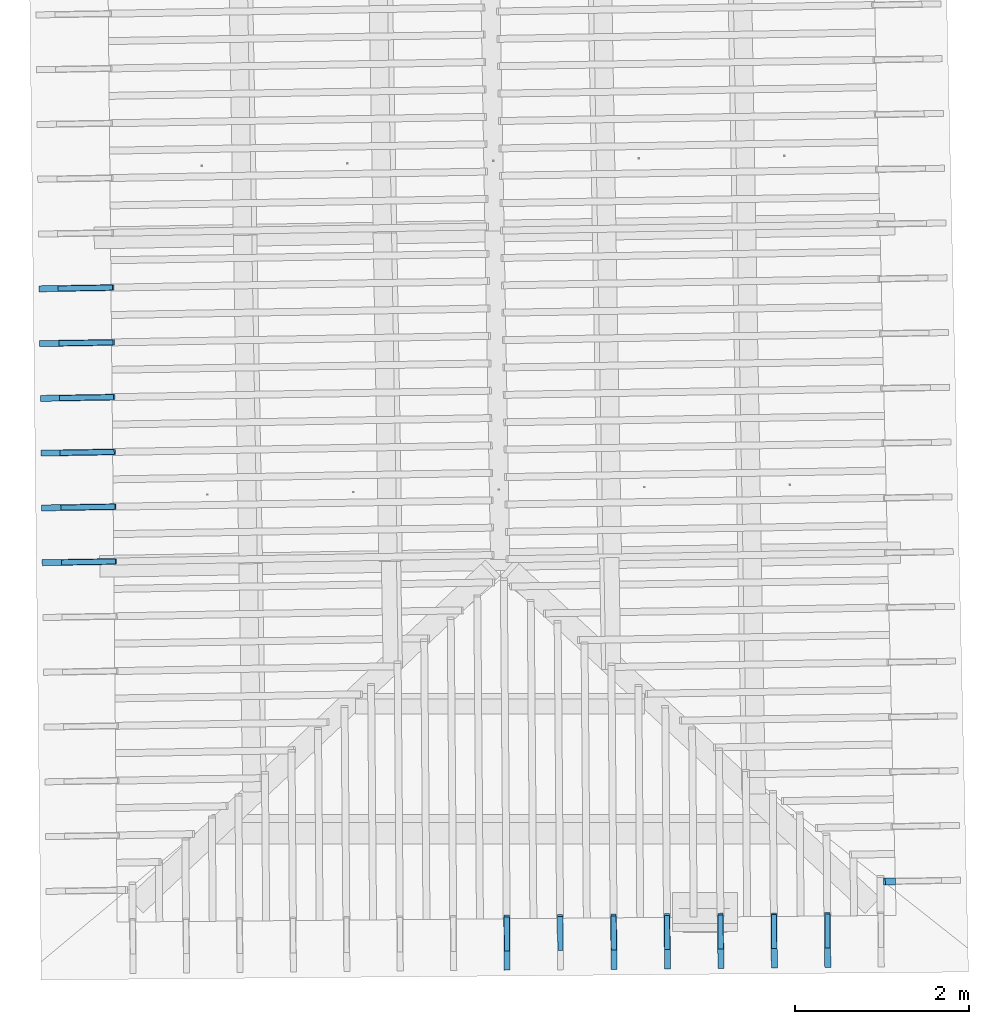
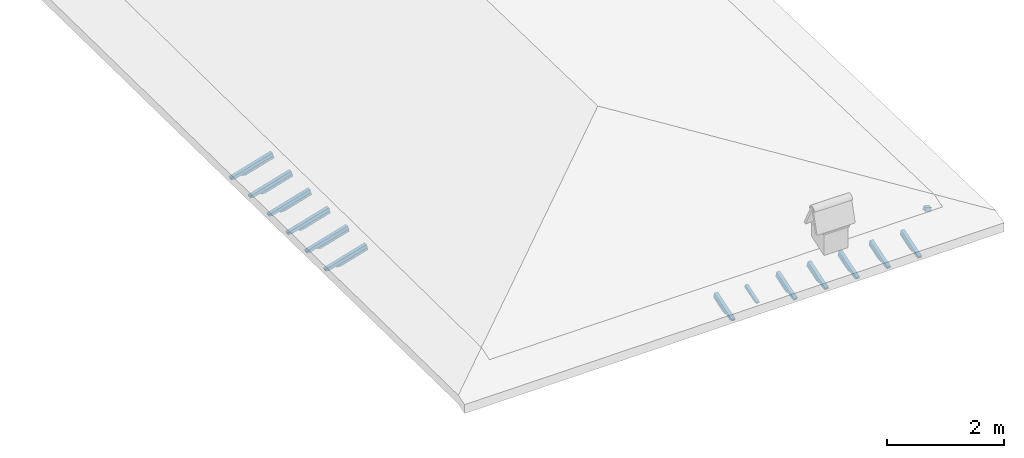
# One storey, part 10 of 19: 26 beams, 5 elements without a shape of their own.
"""IFC4 building model written with IfcOpenShell, lengths in metres."""

import ifcopenshell
import ifcopenshell.guid

model = None  # the IFC model being written
_history = None  # IfcOwnerHistory: only IFC2X3 demands one
_inside = {}  # id of a spatial element -> (the spatial element, [elements in it])
_under = {}  # id of a project, library or spatial element -> (it, [spatial elements below it])
_declared = {}  # id of a project -> (the project, [libraries it declares])
_typed = {}  # id of a type object -> (the type object, [elements of that type])
_made_of = {}  # id of a material, layer set ... -> (it, [elements and type objects made of it])


def new_model(schema):
    """Start an empty IFC model of exactly this schema.

    Asked for "IFC4X3", IfcOpenShell would pick the latest addendum, in which some entities
    have other attributes; the version numbers below select the first issue.
    IFC2X3 requires an IfcOwnerHistory on every rooted entity: one is made here for all.
    """
    global model, _history
    if schema == "IFC4X3":
        model = ifcopenshell.file(schema_version=(4, 3, 0, 0))
    else:
        model = ifcopenshell.file(schema=schema)
    _inside.clear()
    _under.clear()
    _declared.clear()
    _typed.clear()
    _made_of.clear()
    _history = None
    if model.schema == "IFC2X3":
        org = make("IfcOrganization", Name="unknown")
        user = make(
            "IfcPersonAndOrganization",
            ThePerson=make("IfcPerson", FamilyName="unknown"),
            TheOrganization=org,
        )
        app = make(
            "IfcApplication",
            ApplicationDeveloper=org,
            Version="unknown",
            ApplicationFullName="unknown",
            ApplicationIdentifier="unknown",
        )
        _history = make(
            "IfcOwnerHistory",
            OwningUser=user,
            OwningApplication=app,
            ChangeAction="ADDED",
            CreationDate=0,
        )
    return model


def make(cls, **values):
    """One entity of the class cls with the attributes given. An attribute that is None is left unset."""
    return model.create_entity(
        cls, **{name: value for name, value in values.items() if value is not None}
    )


def entity(cls, *values):
    """Any entity or typed value of the class cls, its attributes in the order of the schema. None: left unset."""
    e = model.create_entity(cls)
    for i, value in enumerate(values):
        if value is not None:
            e[i] = value
    return e


def rooted(cls, **values):
    """An entity with a GlobalId (a new one), such as an element, a storey or a relation."""
    return make(cls, GlobalId=ifcopenshell.guid.new(), OwnerHistory=_history, **values)


def si_unit(unit_type, name, prefix=None):
    """IfcSIUnit, for example si_unit("LENGTHUNIT", "METRE", prefix="MILLI")."""
    return make("IfcSIUnit", UnitType=unit_type, Prefix=prefix, Name=name)


def converted_unit(unit_type, name, factor, base, dimensions=None, offset=None):
    """IfcConversionBasedUnit, such as the inch: factor (a typed value) times the base unit."""
    return make(
        "IfcConversionBasedUnit"
        if offset is None
        else "IfcConversionBasedUnitWithOffset",
        ConversionOffset=offset,
        Dimensions=None
        if dimensions is None
        else entity("IfcDimensionalExponents", *dimensions),
        UnitType=unit_type,
        Name=name,
        ConversionFactor=make(
            "IfcMeasureWithUnit", ValueComponent=factor, UnitComponent=base
        ),
    )


def derived_unit(unit_type, elements):
    """IfcDerivedUnit: a product of units, each with its exponent."""
    return make(
        "IfcDerivedUnit",
        Elements=[
            make("IfcDerivedUnitElement", Unit=unit, Exponent=power)
            for unit, power in elements
        ],
        UnitType=unit_type,
    )


def assignment(units):
    """IfcUnitAssignment: the units of a project."""
    return None if units is None else make("IfcUnitAssignment", Units=units)


def point(xyz):
    """IfcCartesianPoint."""
    return None if xyz is None else make("IfcCartesianPoint", Coordinates=xyz)


def direction(xyz):
    """IfcDirection."""
    return None if xyz is None else make("IfcDirection", DirectionRatios=xyz)


def frame(location, z_axis=None, x_axis=None):
    """IfcAxis2Placement3D, a coordinate frame: its origin and axes. An axis left out is left unset."""
    return make(
        "IfcAxis2Placement3D",
        Location=point(location),
        Axis=direction(z_axis),
        RefDirection=direction(x_axis),
    )


def origin():
    """The frame at (0, 0, 0) with its axes left unset."""
    return frame((0.0, 0.0, 0.0))


def place(relative_to, where):
    """IfcLocalPlacement: puts the frame where relative to a parent placement (None: the world)."""
    return make(
        "IfcLocalPlacement", PlacementRelTo=relative_to, RelativePlacement=where
    )


def context(
    kind, dimensions, precision=None, world=None, true_north=None, identifier=None
):
    """IfcGeometricRepresentationContext, for example the 3D "Model" context."""
    return make(
        "IfcGeometricRepresentationContext",
        ContextIdentifier=identifier,
        ContextType=kind,
        CoordinateSpaceDimension=dimensions,
        Precision=precision,
        WorldCoordinateSystem=world,
        TrueNorth=true_north,
    )


def subcontext(parent, identifier, kind, view, scale=None):
    """IfcGeometricRepresentationSubContext, for example "Body" below "Model"."""
    return make(
        "IfcGeometricRepresentationSubContext",
        ContextIdentifier=identifier,
        ContextType=kind,
        ParentContext=parent,
        TargetScale=scale,
        TargetView=view,
    )


def project(units=None, contexts=None):
    """IfcProject with its units and contexts."""
    return rooted(
        "IfcProject",
        Name="project",
        RepresentationContexts=contexts,
        UnitsInContext=assignment(units),
    )


def spatial(cls, under=None, at=None, **own):
    """A site, building, storey or space (cls), placed at a placement, below another one or the project."""
    s = rooted(cls, ObjectPlacement=at, **own)
    if under is not None:
        _under.setdefault(under.id(), (under, []))[1].append(s)
    return s


def point_list(points):
    """IfcCartesianPointList2D or 3D."""
    cls = (
        "IfcCartesianPointList2D" if len(points[0]) == 2 else "IfcCartesianPointList3D"
    )
    return make(cls, CoordList=points)


def line(*indices):
    """IfcLineIndex: a straight run through numbered points of an indexed curve."""
    return model.create_entity("IfcLineIndex", indices)


def arc(*indices):
    """IfcArcIndex: an arc through three numbered points of an indexed curve."""
    return model.create_entity("IfcArcIndex", indices)


def indexed_curve(points, segments=None, self_intersect=None):
    """IfcIndexedPolyCurve: lines and arcs through numbered points (the first is 1)."""
    return make(
        "IfcIndexedPolyCurve",
        Points=point_list(points),
        Segments=segments,
        SelfIntersect=self_intersect,
    )


def outline(outer, holes=None, kind="AREA"):
    """IfcArbitraryClosedProfileDef: a profile drawn as a closed curve; with holes, ...WithVoids."""
    if holes is None:
        return make("IfcArbitraryClosedProfileDef", ProfileType=kind, OuterCurve=outer)
    return make(
        "IfcArbitraryProfileDefWithVoids",
        ProfileType=kind,
        OuterCurve=outer,
        InnerCurves=holes,
    )


def extrude(swept, where, along, depth):
    """IfcExtrudedAreaSolid: the profile swept, set in the frame where, extruded along a direction by depth."""
    return make(
        "IfcExtrudedAreaSolid",
        SweptArea=swept,
        Position=where,
        ExtrudedDirection=direction(along),
        Depth=depth,
    )


def shape(context_of_items, identifier, shape_type, items):
    """IfcShapeRepresentation: the items that make up one representation, for example the "Body"."""
    return make(
        "IfcShapeRepresentation",
        ContextOfItems=context_of_items,
        RepresentationIdentifier=identifier,
        RepresentationType=shape_type,
        Items=items,
    )


def source(mapping_origin, context_of_items, identifier, shape_type, items):
    """IfcRepresentationMap: a shape defined once, which mapped items show again and again."""
    return make(
        "IfcRepresentationMap",
        MappingOrigin=mapping_origin,
        MappedRepresentation=shape(context_of_items, identifier, shape_type, items),
    )


def transform(
    local_origin,
    x_axis=None,
    y_axis=None,
    z_axis=None,
    scale=None,
    scale2=None,
    scale3=None,
    uniform=True,
):
    """IfcCartesianTransformationOperator3D, or its non-uniform kind. x_axis, y_axis, z_axis: its Axis1, 2, 3."""
    if uniform:
        return make(
            "IfcCartesianTransformationOperator3D",
            Axis1=direction(x_axis),
            Axis2=direction(y_axis),
            LocalOrigin=point(local_origin),
            Scale=scale,
            Axis3=direction(z_axis),
        )
    return make(
        "IfcCartesianTransformationOperator3DnonUniform",
        Axis1=direction(x_axis),
        Axis2=direction(y_axis),
        LocalOrigin=point(local_origin),
        Scale=scale,
        Axis3=direction(z_axis),
        Scale2=scale2,
        Scale3=scale3,
    )


def mapped(mapping_source, mapping_target):
    """IfcMappedItem: shows the shape of a source again, moved by a transform."""
    return make(
        "IfcMappedItem", MappingSource=mapping_source, MappingTarget=mapping_target
    )


def material(Name=None, Category=None):
    """IfcMaterial."""
    return make("IfcMaterial", Name=Name, Category=Category)


def made_of(thing, what):
    """Note that an element or type object is made of a material, layer set ...; save() writes the relation."""
    if what is not None:
        _made_of.setdefault(what.id(), (what, []))[1].append(thing)
    return thing


def type_object(cls, material=None, **own):
    """A type object (cls), such as IfcWallType, which elements share."""
    return made_of(rooted(cls, **own), material)


def type_shapes(of_type, sources):
    """Give a type object the sources (RepresentationMaps) that its elements show as mapped items."""
    of_type.RepresentationMaps = sources


def element(
    cls,
    number,
    at=None,
    inside=None,
    cuts=None,
    type_object=None,
    material=None,
    context=None,
    identifier="Body",
    shape_type=None,
    held_by="IfcProductDefinitionShape",
    body=None,
    shapes=None,
    **own,
):
    """One element of the class cls, such as IfcWall. Its Tag is "e" and its number.

    at: its placement. inside: the storey or other place that contains it. cuts: it is an
    opening in that element (IfcRelVoidsElement). A single representation is given by context,
    identifier, shape_type and body (its items); several are given by shapes. held_by: the class
    of the entity that holds the representations. save() writes the other relations.
    """
    e = rooted(cls, Tag="e%d" % number, ObjectPlacement=at, **own)
    if body is not None:
        shapes = [shape(context, identifier, shape_type, body)]
    if shapes is not None:
        e.Representation = make(held_by, Representations=shapes)
    if inside is not None:
        _inside.setdefault(inside.id(), (inside, []))[1].append(e)
    if cuts is not None:
        rooted(
            "IfcRelVoidsElement", RelatingBuildingElement=cuts, RelatedOpeningElement=e
        )
    if type_object is not None:
        _typed.setdefault(type_object.id(), (type_object, []))[1].append(e)
    return made_of(e, material)


def aggregate(whole, parts):
    """IfcRelAggregates: a whole, such as a stair, and the parts it consists of."""
    return rooted("IfcRelAggregates", RelatingObject=whole, RelatedObjects=parts)


def save(model, path):
    """Write the relations noted so far, then the file.

    IfcRelAggregates (storeys below a building ...), IfcRelContainedInSpatialStructure (elements
    in a storey), IfcRelDefinesByType, IfcRelAssociatesMaterial and IfcRelDeclares: one each for
    every whole, place, type object, material and project.
    """
    for whole, parts in _under.values():
        aggregate(whole, parts)
    for where, things in _inside.values():
        rooted(
            "IfcRelContainedInSpatialStructure",
            RelatedElements=things,
            RelatingStructure=where,
        )
    for kind, things in _typed.values():
        rooted("IfcRelDefinesByType", RelatedObjects=things, RelatingType=kind)
    for what, things in _made_of.values():
        rooted("IfcRelAssociatesMaterial", RelatedObjects=things, RelatingMaterial=what)
    for by, libraries in _declared.values():
        rooted("IfcRelDeclares", RelatingContext=by, RelatedDefinitions=libraries)
    model.write(path)


model = new_model("IFC4")

# Units and contexts
model_context = context("Model", 3, precision=1e-05, world=origin(), true_north=direction((6.123233995736766e-17, 1.0)))
body_context = subcontext(model_context, "Body", "Model", "MODEL_VIEW")
ifc_project = project(units=[si_unit("LENGTHUNIT", "METRE"), si_unit("AREAUNIT", "SQUARE_METRE"), si_unit("VOLUMEUNIT", "CUBIC_METRE"), converted_unit("PLANEANGLEUNIT", "DEGREE", entity("IfcPlaneAngleMeasure", 0.017453292519943278), si_unit("PLANEANGLEUNIT", "RADIAN"), dimensions=[0, 0, 0, 0, 0, 0, 0]), derived_unit("THERMALTRANSMITTANCEUNIT", [(si_unit("MASSUNIT", "GRAM", prefix="KILO"), 1), (si_unit("THERMODYNAMICTEMPERATUREUNIT", "KELVIN"), -1), (si_unit("TIMEUNIT", "SECOND"), -3)])], contexts=[model_context])

# Site, building, storey
site_placement = place(None, origin())
site = spatial("IfcSite", under=ifc_project, at=site_placement, CompositionType="ELEMENT")
building_placement = place(site_placement, origin())
building = spatial("IfcBuilding", under=site, at=building_placement, CompositionType="ELEMENT")
storey_placement = place(building_placement, frame((0.0, 0.0, 3.28)))
storey = spatial("IfcBuildingStorey", under=building, at=storey_placement, Name="Livello Copertura", CompositionType="ELEMENT", Elevation=3.28)

# Assembly, beam
assembly_1_placement = place(storey_placement, origin())
assembly_1 = element("IfcElementAssembly", 1, at=assembly_1_placement, inside=storey, Name="Sistema di travi strutturali:Sistema di travi strutturali", ObjectType="Sistema di travi strutturali:Sistema di travi strutturali", AssemblyPlace="NOTDEFINED", PredefinedType="BEAM_GRID")
ifc_material = material(Name="Legno - Legno da costruzione", Category="Legno")
beam_type_1 = type_object("IfcBeamType", Name="Legno:80x80", PredefinedType="JOIST", material=ifc_material)
shared_shape_1 = source(origin(), body_context, "Body", "SweptSolid", [
    extrude(outline(indexed_curve([(-0.06, -0.04000000000000169), (0.06, -0.04000000000000169), (0.06, 0.04000000000000169), (-0.06, 0.04000000000000169), (-0.06, -0.04000000000000169)], self_intersect=False)), frame((0.0, 0.0, -0.040000000000005476), z_axis=(0.0, 0.0, 1.0), x_axis=(-1.0, 0.0, 0.0)), (0.0, 0.0, 1.0), 0.07999999999999997),
])
type_shapes(beam_type_1, [shared_shape_1])
beam_1_placement = place(assembly_1_placement, frame((4.366833292213961, -2.753231039773949, 0.09177934520169773), z_axis=(0.2688805697492502, 0.00459446744066822, 0.9631625667976592), x_axis=(-0.9630219859926796, -0.01645553326302712, 0.26891982061526215)))
beam_1 = element("IfcBeam", 2, at=beam_1_placement, type_object=beam_type_1, material=ifc_material, Name="Legno:80x80", ObjectType="Legno:80x80", PredefinedType="JOIST", context=body_context, shape_type="MappedRepresentation", body=[
    mapped(shared_shape_1, transform((0.0, 0.0, 0.0), scale=1.0)),
])
aggregate(assembly_1, [beam_1])

# Assembly, beams
assembly_2_placement = place(storey_placement, origin())
assembly_2 = element("IfcElementAssembly", 3, at=assembly_2_placement, inside=storey, Name="Sistema di travi strutturali:Sistema di travi strutturali", ObjectType="Sistema di travi strutturali:Sistema di travi strutturali", AssemblyPlace="NOTDEFINED", PredefinedType="BEAM_GRID")
beam_type_2 = type_object("IfcBeamType", Name="70x70:70x70", PredefinedType="JOIST", material=ifc_material)
shared_shape_2 = source(origin(), body_context, "Body", "SweptSolid", [
    extrude(outline(indexed_curve([(-0.04357142857143147, -0.5739999999999993), (0.02642857142856851, -0.5739999999999993), (0.02642857142856851, 0.18000000000000033), (0.01242857142858439, 0.17999999999999694), (0.026181867029378907, 0.20370960452790157), (0.018428571428570677, 0.23000000000000062), (0.006014118110847642, 0.25299557551498353), (0.003428571428570844, 0.2790000000000004), (-0.04357142857143147, 0.2790000000000004)], segments=[line(1, 2, 3, 4), arc(4, 5, 6), arc(6, 7, 8), line(8, 9, 1)], self_intersect=False)), frame((-0.11249999999999936, -0.03500000000000078, -0.008571428571433209), z_axis=(0.0, 1.0, 0.0), x_axis=(0.0, 0.0, -1.0)), (0.0, 0.0, 1.0), 0.06999999999999999),
])
type_shapes(beam_type_2, [shared_shape_2])
beam_2_placement = place(assembly_2_placement, frame((-4.988717104860706, 0.9183690082744996, 0.09825853585725741), z_axis=(-0.26888056974925334, -0.004594467440668785, 0.9631625667976583), x_axis=(0.9630219859926786, 0.016455533263033065, 0.2689198206152653)))
beam_2 = element("IfcBeam", 4, at=beam_2_placement, type_object=beam_type_2, material=ifc_material, Name="70x70:70x70", ObjectType="70x70:70x70", PredefinedType="JOIST", context=body_context, shape_type="MappedRepresentation", body=[
    mapped(shared_shape_2, transform((0.0, 0.0, 0.0), scale=1.0)),
])
beam_type_3 = type_object("IfcBeamType", Name="70x70:70x70", PredefinedType="JOIST", material=ifc_material)
shared_shape_3 = source(origin(), body_context, "Body", "SweptSolid", [
    extrude(outline(indexed_curve([(-0.04357142857143148, -0.575428571428571), (0.02642857142856849, -0.575428571428571), (0.02642857142856849, 0.18057142857142902), (0.012428571428584383, 0.18057142857142564), (0.0261818670293789, 0.20428103309933027), (0.018428571428570715, 0.23057142857142915), (0.006014118110847679, 0.2535670040864121), (0.00342857142857088, 0.27957142857142897), (-0.04357142857143148, 0.27957142857142897)], segments=[line(1, 2, 3, 4), arc(4, 5, 6), arc(6, 7, 8), line(8, 9, 1)], self_intersect=False)), frame((-0.11292857142857085, -0.03500000000000078, -0.008571428571433224), z_axis=(0.0, 1.0, 0.0), x_axis=(0.0, 0.0, -1.0)), (0.0, 0.0, 1.0), 0.06999999999999999),
])
type_shapes(beam_type_3, [shared_shape_3])
beam_3_placement = place(assembly_2_placement, frame((-4.995498480005348, 1.5483450989168117, 0.09937052324256612), z_axis=(-0.2688805697492535, -0.004594467440668792, 0.9631625667976582), x_axis=(0.9630219859926785, 0.016455533263032975, 0.2689198206152655)))
beam_3 = element("IfcBeam", 5, at=beam_3_placement, type_object=beam_type_3, material=ifc_material, Name="70x70:70x70", ObjectType="70x70:70x70", PredefinedType="JOIST", context=body_context, shape_type="MappedRepresentation", body=[
    mapped(shared_shape_3, transform((0.0, 0.0, 0.0), scale=1.0)),
])
beam_type_4 = type_object("IfcBeamType", Name="70x70:70x70", PredefinedType="JOIST", material=ifc_material)
shared_shape_4 = source(origin(), body_context, "Body", "SweptSolid", [
    extrude(outline(indexed_curve([(-0.04357142857143152, -0.5761428571428567), (0.026428571428568467, -0.5761428571428567), (0.026428571428568467, 0.18085714285714335), (0.012428571428584369, 0.18085714285714), (0.026181867029378886, 0.20456674738504463), (0.018428571428570784, 0.2308571428571435), (0.006014118110847748, 0.2538527183721264), (0.003428571428570954, 0.2798571428571433), (-0.04357142857143152, 0.2798571428571433)], segments=[line(1, 2, 3, 4), arc(4, 5, 6), arc(6, 7, 8), line(8, 9, 1)], self_intersect=False)), frame((-0.11314285714285667, -0.03500000000000078, -0.008571428571433256), z_axis=(0.0, 1.0, 0.0), x_axis=(0.0, 0.0, -1.0)), (0.0, 0.0, 1.0), 0.06999999999999999),
])
type_shapes(beam_type_4, [shared_shape_4])
beam_4_placement = place(assembly_2_placement, frame((-5.002279855149992, 2.1783211895591243, 0.1004825106278755), z_axis=(-0.26888056974925373, -0.00459446744066879, 0.9631625667976582), x_axis=(0.9630219859926785, 0.016455533263033312, 0.26891982061526565)))
beam_4 = element("IfcBeam", 6, at=beam_4_placement, type_object=beam_type_4, material=ifc_material, Name="70x70:70x70", ObjectType="70x70:70x70", PredefinedType="JOIST", context=body_context, shape_type="MappedRepresentation", body=[
    mapped(shared_shape_4, transform((0.0, 0.0, 0.0), scale=1.0)),
])
beam_type_5 = type_object("IfcBeamType", Name="70x70:70x70", PredefinedType="JOIST", material=ifc_material)
shared_shape_5 = source(origin(), body_context, "Body", "SweptSolid", [
    extrude(outline(indexed_curve([(-0.043571428571431495, -0.5768571428571425), (0.026428571428568495, -0.5768571428571425), (0.026428571428568495, 0.18114285714285766), (0.012428571428584398, 0.18114285714285427), (0.026181867029378917, 0.2048524616707589), (0.01842857142857071, 0.2311428571428578), (0.006014118110847676, 0.2541384326578407), (0.003428571428570882, 0.28014285714285764), (-0.043571428571431495, 0.28014285714285764)], segments=[line(1, 2, 3, 4), arc(4, 5, 6), arc(6, 7, 8), line(8, 9, 1)], self_intersect=False)), frame((-0.1133571428571424, -0.03500000000000078, -0.008571428571433226), z_axis=(0.0, 1.0, 0.0), x_axis=(0.0, 0.0, -1.0)), (0.0, 0.0, 1.0), 0.06999999999999999),
])
type_shapes(beam_type_5, [shared_shape_5])
beam_5_placement = place(assembly_2_placement, frame((-5.009061230294636, 2.8082972802014354, 0.10159449801318532), z_axis=(-0.26888056974925334, -0.004594467440668783, 0.9631625667976584), x_axis=(0.9630219859926786, 0.016455533263033364, 0.26891982061526526)))
beam_5 = element("IfcBeam", 7, at=beam_5_placement, type_object=beam_type_5, material=ifc_material, Name="70x70:70x70", ObjectType="70x70:70x70", PredefinedType="JOIST", context=body_context, shape_type="MappedRepresentation", body=[
    mapped(shared_shape_5, transform((0.0, 0.0, 0.0), scale=1.0)),
])
beam_type_6 = type_object("IfcBeamType", Name="70x70:70x70", PredefinedType="JOIST", material=ifc_material)
shared_shape_6 = source(origin(), body_context, "Body", "SweptSolid", [
    extrude(outline(indexed_curve([(-0.04357142857143154, -0.5775714285714282), (0.02642857142856845, -0.5775714285714282), (0.02642857142856845, 0.18142857142857194), (0.01242857142858435, 0.18142857142856855), (0.026181867029378865, 0.20513817595647318), (0.018428571428570833, 0.2314285714285721), (0.006014118110847797, 0.254424146943555), (0.0034285714285710025, 0.2804285714285719), (-0.04357142857143154, 0.2804285714285719)], segments=[line(1, 2, 3, 4), arc(4, 5, 6), arc(6, 7, 8), line(8, 9, 1)], self_intersect=False)), frame((-0.11357142857142812, -0.03500000000000078, -0.008571428571433275), z_axis=(0.0, 1.0, 0.0), x_axis=(0.0, 0.0, -1.0)), (0.0, 0.0, 1.0), 0.06999999999999999),
])
type_shapes(beam_type_6, [shared_shape_6])
beam_6_placement = place(assembly_2_placement, frame((-5.015842605439279, 3.4382733708437465, 0.10270648539849314), z_axis=(-0.26888056974925306, -0.004594467440668781, 0.9631625667976583), x_axis=(0.9630219859926786, 0.016455533263033437, 0.26891982061526504)))
beam_6 = element("IfcBeam", 8, at=beam_6_placement, type_object=beam_type_6, material=ifc_material, Name="70x70:70x70", ObjectType="70x70:70x70", PredefinedType="JOIST", context=body_context, shape_type="MappedRepresentation", body=[
    mapped(shared_shape_6, transform((0.0, 0.0, 0.0), scale=1.0)),
])
beam_type_7 = type_object("IfcBeamType", Name="70x70:70x70", PredefinedType="JOIST", material=ifc_material)
shared_shape_7 = source(origin(), body_context, "Body", "SweptSolid", [
    extrude(outline(indexed_curve([(-0.04357142857143151, -0.5789999999999995), (0.026428571428568484, -0.5789999999999995), (0.026428571428568484, 0.1820000000000005), (0.012428571428584384, 0.1819999999999971), (0.026181867029378903, 0.20570960452790174), (0.01842857142857075, 0.23200000000000062), (0.006014118110847714, 0.25499557551498353), (0.0034285714285709197, 0.28100000000000047), (-0.04357142857143151, 0.28100000000000047)], segments=[line(1, 2, 3, 4), arc(4, 5, 6), arc(6, 7, 8), line(8, 9, 1)], self_intersect=False)), frame((-0.1139999999999995, -0.03500000000000078, -0.008571428571433238), z_axis=(0.0, 1.0, 0.0), x_axis=(0.0, 0.0, -1.0)), (0.0, 0.0, 1.0), 0.06999999999999999),
])
type_shapes(beam_type_7, [shared_shape_7])
beam_7_placement = place(assembly_2_placement, frame((-5.022623980583923, 4.068249461486059, 0.10381847278380252), z_axis=(-0.2688805697492529, -0.004594467440668775, 0.9631625667976585), x_axis=(0.9630219859926787, 0.01645553326303291, 0.2689198206152648)))
beam_7 = element("IfcBeam", 9, at=beam_7_placement, type_object=beam_type_7, material=ifc_material, Name="70x70:70x70", ObjectType="70x70:70x70", PredefinedType="JOIST", context=body_context, shape_type="MappedRepresentation", body=[
    mapped(shared_shape_7, transform((0.0, 0.0, 0.0), scale=1.0)),
])
aggregate(assembly_2, [beam_2, beam_3, beam_4, beam_5, beam_6, beam_7])

assembly_3_placement = place(storey_placement, origin())
assembly_3 = element("IfcElementAssembly", 10, at=assembly_3_placement, inside=storey, Name="Sistema di travi strutturali:Sistema di travi strutturali", ObjectType="Sistema di travi strutturali:Sistema di travi strutturali", AssemblyPlace="NOTDEFINED", PredefinedType="BEAM_GRID")
beam_type_8 = type_object("IfcBeamType", Name="60x60:60x60", PredefinedType="JOIST", material=ifc_material)
shared_shape_8 = source(origin(), body_context, "Body", "SweptSolid", [
    extrude(outline(indexed_curve([(-0.03585714285711788, -0.4227142857142859), (0.024142857142882102, -0.4227142857142859), (0.024142857142882102, 0.12128571428571412), (0.007142857142882163, 0.12128571428571412), (0.022800314198399098, 0.13888213034128186), (0.020142857142794308, 0.16228571428571525), (0.006097362558745509, 0.19043930273369505), (-0.0038571428572049074, 0.22028571428571408), (-0.03585714285711788, 0.22028571428571417)], segments=[line(1, 2, 3, 4), arc(4, 5, 6), arc(6, 7, 8), line(8, 9, 1)], self_intersect=False)), frame((0.0387857142857142, -0.030000000000000786, -0.005857142857119617), z_axis=(0.0, 1.0, 0.0), x_axis=(0.0, 0.0, -1.0)), (0.0, 0.0, 1.0), 0.059999999999999984),
])
type_shapes(beam_type_8, [shared_shape_8])
beam_8_placement = place(assembly_3_placement, frame((-4.971239867827005, 0.9186676486581431, 0.03565296901540971), z_axis=(-0.26888056974925334, -0.004594467440668785, 0.9631625667976583), x_axis=(0.9630219859926786, 0.016455533263033065, 0.2689198206152653)))
beam_8 = element("IfcBeam", 11, at=beam_8_placement, type_object=beam_type_8, material=ifc_material, Name="60x60:60x60", ObjectType="60x60:60x60", PredefinedType="JOIST", context=body_context, shape_type="MappedRepresentation", body=[
    mapped(shared_shape_8, transform((0.0, 0.0, 0.0), scale=1.0)),
])
beam_type_9 = type_object("IfcBeamType", Name="60x60:60x60", PredefinedType="JOIST", material=ifc_material)
shared_shape_9 = source(origin(), body_context, "Body", "SweptSolid", [
    extrude(outline(indexed_curve([(-0.03585714285711785, -0.4241428571428574), (0.024142857142882126, -0.4241428571428574), (0.024142857142882126, 0.12185714285714272), (0.007142857142882192, 0.12185714285714272), (0.022800314198399122, 0.13945355891271044), (0.02014285714279423, 0.16285714285714387), (0.0060973625587454365, 0.19101073130512367), (-0.00385714285720498, 0.22085714285714267), (-0.03585714285711785, 0.22085714285714272)], segments=[line(1, 2, 3, 4), arc(4, 5, 6), arc(6, 7, 8), line(8, 9, 1)], self_intersect=False)), frame((0.03835714285714275, -0.030000000000000786, -0.005857142857119588), z_axis=(0.0, 1.0, 0.0), x_axis=(0.0, 0.0, -1.0)), (0.0, 0.0, 1.0), 0.059999999999999984),
])
type_shapes(beam_type_9, [shared_shape_9])
beam_9_placement = place(assembly_3_placement, frame((-4.978021242971647, 1.548643739300455, 0.03676495640071775), z_axis=(-0.2688805697492535, -0.004594467440668792, 0.9631625667976582), x_axis=(0.9630219859926785, 0.016455533263032975, 0.2689198206152655)))
beam_9 = element("IfcBeam", 12, at=beam_9_placement, type_object=beam_type_9, material=ifc_material, Name="60x60:60x60", ObjectType="60x60:60x60", PredefinedType="JOIST", context=body_context, shape_type="MappedRepresentation", body=[
    mapped(shared_shape_9, transform((0.0, 0.0, 0.0), scale=1.0)),
])
beam_type_10 = type_object("IfcBeamType", Name="60x60:60x60", PredefinedType="JOIST", material=ifc_material)
shared_shape_10 = source(origin(), body_context, "Body", "SweptSolid", [
    extrude(outline(indexed_curve([(-0.03585714285711706, -0.4248571428571431), (0.02414285714288292, -0.4248571428571431), (0.02414285714288292, 0.12214285714285712), (0.0071428571428830585, 0.1221428571428571), (0.022800314198399986, 0.1397392731984248), (0.02014285714279222, 0.16314285714285803), (0.00609736255874342, 0.1912964455908378), (-0.003857142857206997, 0.22114285714285686), (-0.03585714285711706, 0.22114285714285717)], segments=[line(1, 2, 3, 4), arc(4, 5, 6), arc(6, 7, 8), line(8, 9, 1)], self_intersect=False)), frame((0.038142857142856944, -0.030000000000000786, -0.005857142857118796), z_axis=(0.0, 1.0, 0.0), x_axis=(0.0, 0.0, -1.0)), (0.0, 0.0, 1.0), 0.059999999999999984),
])
type_shapes(beam_type_10, [shared_shape_10])
beam_10_placement = place(assembly_3_placement, frame((-4.9848026181162925, 2.1786198299427677, 0.03787694378602713), z_axis=(-0.26888056974925373, -0.00459446744066879, 0.9631625667976582), x_axis=(0.9630219859926785, 0.016455533263033312, 0.26891982061526565)))
beam_10 = element("IfcBeam", 13, at=beam_10_placement, type_object=beam_type_10, material=ifc_material, Name="60x60:60x60", ObjectType="60x60:60x60", PredefinedType="JOIST", context=body_context, shape_type="MappedRepresentation", body=[
    mapped(shared_shape_10, transform((0.0, 0.0, 0.0), scale=1.0)),
])
beam_type_11 = type_object("IfcBeamType", Name="60x60:60x60", PredefinedType="JOIST", material=ifc_material)
shared_shape_11 = source(origin(), body_context, "Body", "SweptSolid", [
    extrude(outline(indexed_curve([(-0.035857142857117705, -0.4255714285714288), (0.024142857142882276, -0.4255714285714288), (0.024142857142882276, 0.12242857142857132), (0.007142857142882338, 0.12242857142857132), (0.02280031419839927, 0.14002498748413905), (0.020142857142793874, 0.16342857142857245), (0.006097362558745075, 0.19158215987655222), (-0.003857142857205342, 0.22142857142857128), (-0.035857142857117705, 0.22142857142857134)], segments=[line(1, 2, 3, 4), arc(4, 5, 6), arc(6, 7, 8), line(8, 9, 1)], self_intersect=False)), frame((0.037928571428571305, -0.030000000000000786, -0.005857142857119442), z_axis=(0.0, 1.0, 0.0), x_axis=(0.0, 0.0, -1.0)), (0.0, 0.0, 1.0), 0.059999999999999984),
])
type_shapes(beam_type_11, [shared_shape_11])
beam_11_placement = place(assembly_3_placement, frame((-4.991583993260934, 2.8085959205850783, 0.03898893117133717), z_axis=(-0.26888056974925334, -0.004594467440668783, 0.9631625667976584), x_axis=(0.9630219859926786, 0.016455533263033364, 0.26891982061526526)))
beam_11 = element("IfcBeam", 14, at=beam_11_placement, type_object=beam_type_11, material=ifc_material, Name="60x60:60x60", ObjectType="60x60:60x60", PredefinedType="JOIST", context=body_context, shape_type="MappedRepresentation", body=[
    mapped(shared_shape_11, transform((0.0, 0.0, 0.0), scale=1.0)),
])
beam_type_12 = type_object("IfcBeamType", Name="60x60:60x60", PredefinedType="JOIST", material=ifc_material)
shared_shape_12 = source(origin(), body_context, "Body", "SweptSolid", [
    extrude(outline(indexed_curve([(-0.03585714285711781, -0.42628571428571455), (0.024142857142882168, -0.42628571428571455), (0.024142857142882168, 0.12271428571428562), (0.007142857142882231, 0.12271428571428562), (0.022800314198399167, 0.14031070176985336), (0.02014285714279414, 0.16371428571428673), (0.00609736255874534, 0.19186787416226653), (-0.0038571428572050765, 0.22171428571428556), (-0.03585714285711781, 0.22171428571428564)], segments=[line(1, 2, 3, 4), arc(4, 5, 6), arc(6, 7, 8), line(8, 9, 1)], self_intersect=False)), frame((0.03771428571428558, -0.030000000000000786, -0.005857142857119549), z_axis=(0.0, 1.0, 0.0), x_axis=(0.0, 0.0, -1.0)), (0.0, 0.0, 1.0), 0.059999999999999984),
])
type_shapes(beam_type_12, [shared_shape_12])
beam_12_placement = place(assembly_3_placement, frame((-4.998365368405578, 3.43857201122739, 0.04010091855664499), z_axis=(-0.26888056974925306, -0.004594467440668781, 0.9631625667976583), x_axis=(0.9630219859926786, 0.016455533263033437, 0.26891982061526504)))
beam_12 = element("IfcBeam", 15, at=beam_12_placement, type_object=beam_type_12, material=ifc_material, Name="60x60:60x60", ObjectType="60x60:60x60", PredefinedType="JOIST", context=body_context, shape_type="MappedRepresentation", body=[
    mapped(shared_shape_12, transform((0.0, 0.0, 0.0), scale=1.0)),
])
beam_type_13 = type_object("IfcBeamType", Name="60x60:60x60", PredefinedType="JOIST", material=ifc_material)
shared_shape_13 = source(origin(), body_context, "Body", "SweptSolid", [
    extrude(outline(indexed_curve([(-0.035857142857117844, -0.4277142857142859), (0.02414285714288214, -0.4277142857142859), (0.02414285714288214, 0.12328571428571412), (0.0071428571428822024, 0.12328571428571412), (0.022800314198399136, 0.14088213034128186), (0.02014285714279421, 0.16428571428571528), (0.006097362558745414, 0.19243930273369506), (-0.003857142857205003, 0.22228571428571411), (-0.035857142857117844, 0.22228571428571417)], segments=[line(1, 2, 3, 4), arc(4, 5, 6), arc(6, 7, 8), line(8, 9, 1)], self_intersect=False)), frame((0.037285714285714186, -0.030000000000000786, -0.005857142857119578), z_axis=(0.0, 1.0, 0.0), x_axis=(0.0, 0.0, -1.0)), (0.0, 0.0, 1.0), 0.059999999999999984),
])
type_shapes(beam_type_13, [shared_shape_13])
beam_13_placement = place(assembly_3_placement, frame((-5.005146743550221, 4.068548101869703, 0.04121290594195437), z_axis=(-0.2688805697492529, -0.004594467440668775, 0.9631625667976585), x_axis=(0.9630219859926787, 0.01645553326303291, 0.2689198206152648)))
beam_13 = element("IfcBeam", 16, at=beam_13_placement, type_object=beam_type_13, material=ifc_material, Name="60x60:60x60", ObjectType="60x60:60x60", PredefinedType="JOIST", context=body_context, shape_type="MappedRepresentation", body=[
    mapped(shared_shape_13, transform((0.0, 0.0, 0.0), scale=1.0)),
])
aggregate(assembly_3, [beam_8, beam_9, beam_10, beam_11, beam_12, beam_13])

assembly_4_placement = place(storey_placement, origin())
assembly_4 = element("IfcElementAssembly", 17, at=assembly_4_placement, inside=storey, Name="Sistema di travi strutturali:Sistema di travi strutturali", ObjectType="Sistema di travi strutturali:Sistema di travi strutturali", AssemblyPlace="NOTDEFINED", PredefinedType="BEAM_GRID")
beam_type_14 = type_object("IfcBeamType", Name="70x70:70x70", PredefinedType="JOIST", material=ifc_material)
shared_shape_14 = source(origin(), body_context, "Body", "SweptSolid", [
    extrude(outline(indexed_curve([(-0.043571428571431474, -0.4118571428571424), (0.026428571428568512, -0.4118571428571424), (0.026428571428568512, 0.1151428571428576), (0.012428571428584416, 0.11514285714285424), (0.02618186702937893, 0.13885246167075888), (0.018428571428570677, 0.16514285714285784), (0.006014118110847642, 0.1881384326578407), (0.003428571428570848, 0.21414285714285763), (-0.043571428571431474, 0.21414285714285763)], segments=[line(1, 2, 3, 4), arc(4, 5, 6), arc(6, 7, 8), line(8, 9, 1)], self_intersect=False)), frame((-0.06385714285714238, -0.03500000000000078, -0.008571428571433209), z_axis=(0.0, 1.0, 0.0), x_axis=(0.0, 0.0, -1.0)), (0.0, 0.0, 1.0), 0.06999999999999999),
])
type_shapes(beam_type_14, [shared_shape_14])
beam_14_placement = place(assembly_4_placement, frame((3.6567599247723295, -3.468652351066602, 0.0004209574836433472), z_axis=(0.0033933227624359935, -0.32555047006150906, 0.9455185755993166), x_axis=(-0.007932350194779494, 0.9454855083215802, 0.32556755270491944)))
beam_14 = element("IfcBeam", 18, at=beam_14_placement, type_object=beam_type_14, material=ifc_material, Name="70x70:70x70", ObjectType="70x70:70x70", PredefinedType="JOIST", context=body_context, shape_type="MappedRepresentation", body=[
    mapped(shared_shape_14, transform((0.0, 0.0, 0.0), scale=1.0)),
])
beam_15_placement = place(assembly_4_placement, frame((3.0421826619890227, -3.473924541118054, 0.0008113200583192981), z_axis=(0.0033933227624359866, -0.32555047006150833, 0.9455185755993168), x_axis=(-0.007932350194779943, 0.9454855083215805, 0.32556755270491866)))
beam_15 = element("IfcBeam", 19, at=beam_15_placement, type_object=beam_type_14, material=ifc_material, Name="70x70:70x70", ObjectType="70x70:70x70", PredefinedType="JOIST", context=body_context, shape_type="MappedRepresentation", body=[
    mapped(shared_shape_14, transform((0.0, 0.0, 0.0), scale=1.0)),
])
beam_16_placement = place(assembly_4_placement, frame((2.427605399205718, -3.4791967311695062, 0.001201682632995027), z_axis=(0.0033933227624359866, -0.32555047006150833, 0.9455185755993168), x_axis=(-0.007932350194779612, 0.9454855083215805, 0.32556755270491866)))
beam_16 = element("IfcBeam", 20, at=beam_16_placement, type_object=beam_type_14, material=ifc_material, Name="70x70:70x70", ObjectType="70x70:70x70", PredefinedType="JOIST", context=body_context, shape_type="MappedRepresentation", body=[
    mapped(shared_shape_14, transform((0.0, 0.0, 0.0), scale=1.0)),
])
beam_17_placement = place(assembly_4_placement, frame((1.8130281364224143, -3.4844689212209574, 0.0015920452076705338), z_axis=(0.0033933227624359926, -0.325550470061509, 0.9455185755993166), x_axis=(-0.00793235019477967, 0.9454855083215802, 0.3255675527049194)))
beam_17 = element("IfcBeam", 21, at=beam_17_placement, type_object=beam_type_14, material=ifc_material, Name="70x70:70x70", ObjectType="70x70:70x70", PredefinedType="JOIST", context=body_context, shape_type="MappedRepresentation", body=[
    mapped(shared_shape_14, transform((0.0, 0.0, 0.0), scale=1.0)),
])
beam_18_placement = place(assembly_4_placement, frame((1.1984508736391084, -3.4897411112724086, 0.0019824077823458186), z_axis=(0.00339332276243599, -0.3255504700615087, 0.9455185755993167), x_axis=(-0.007932350194779723, 0.9454855083215803, 0.3255675527049191)))
beam_18 = element("IfcBeam", 22, at=beam_18_placement, type_object=beam_type_14, material=ifc_material, Name="70x70:70x70", ObjectType="70x70:70x70", PredefinedType="JOIST", context=body_context, shape_type="MappedRepresentation", body=[
    mapped(shared_shape_14, transform((0.0, 0.0, 0.0), scale=1.0)),
])
beam_19_placement = place(assembly_4_placement, frame((-0.030703651927501893, -3.5002854913753123, 0.0027631329316972764), z_axis=(0.003393322762435989, -0.32555047006150867, 0.9455185755993167), x_axis=(-0.007932350194779572, 0.9454855083215803, 0.32556755270491905)))
beam_19 = element("IfcBeam", 23, at=beam_19_placement, type_object=beam_type_14, material=ifc_material, Name="70x70:70x70", ObjectType="70x70:70x70", PredefinedType="JOIST", context=body_context, shape_type="MappedRepresentation", body=[
    mapped(shared_shape_14, transform((0.0, 0.0, 0.0), scale=1.0)),
])
aggregate(assembly_4, [beam_14, beam_15, beam_16, beam_17, beam_18, beam_19])

assembly_5_placement = place(storey_placement, origin())
assembly_5 = element("IfcElementAssembly", 24, at=assembly_5_placement, inside=storey, Name="Sistema di travi strutturali:Sistema di travi strutturali", ObjectType="Sistema di travi strutturali:Sistema di travi strutturali", AssemblyPlace="NOTDEFINED", PredefinedType="BEAM_GRID")
beam_type_15 = type_object("IfcBeamType", Name="60x60:60x60", PredefinedType="JOIST", material=ifc_material)
shared_shape_15 = source(origin(), body_context, "Body", "SweptSolid", [
    extrude(outline(indexed_curve([(-0.035857142857118045, -0.26057142857142884), (0.024142857142881936, -0.26057142857142884), (0.024142857142881936, 0.05642857142857127), (0.0071428571428819995, 0.05642857142857127), (0.022800314198398935, 0.07402498748413901), (0.02014285714279472, 0.0974285714285724), (0.006097362558745921, 0.1255821598765522), (-0.003857142857204496, 0.15542857142857122), (-0.035857142857118045, 0.15542857142857128)], segments=[line(1, 2, 3, 4), arc(4, 5, 6), arc(6, 7, 8), line(8, 9, 1)], self_intersect=False)), frame((0.08742857142857127, -0.030000000000000786, -0.005857142857119781), z_axis=(0.0, 1.0, 0.0), x_axis=(0.0, 0.0, -1.0)), (0.0, 0.0, 1.0), 0.059999999999999984),
])
type_shapes(beam_type_15, [shared_shape_15])
beam_20_placement = place(assembly_5_placement, frame((3.6565393587927693, -3.4474915705126046, -0.061037749930311413), z_axis=(0.0033933227624359935, -0.3255504700615091, 0.9455185755993165), x_axis=(-0.007932350194779494, 0.9454855083215802, 0.32556755270491944)))
beam_20 = element("IfcBeam", 25, at=beam_20_placement, type_object=beam_type_15, material=ifc_material, Name="60x60:60x60", ObjectType="60x60:60x60", PredefinedType="JOIST", context=body_context, shape_type="MappedRepresentation", body=[
    mapped(shared_shape_15, transform((0.0, 0.0, 0.0), scale=1.0)),
])
beam_21_placement = place(assembly_5_placement, frame((3.0419620960094655, -3.4527637605640558, -0.06064738735563591), z_axis=(0.0033933227624359883, -0.32555047006150833, 0.9455185755993168), x_axis=(-0.007932350194779943, 0.9454855083215805, 0.32556755270491866)))
beam_21 = element("IfcBeam", 26, at=beam_21_placement, type_object=beam_type_15, material=ifc_material, Name="60x60:60x60", ObjectType="60x60:60x60", PredefinedType="JOIST", context=body_context, shape_type="MappedRepresentation", body=[
    mapped(shared_shape_15, transform((0.0, 0.0, 0.0), scale=1.0)),
])
beam_22_placement = place(assembly_5_placement, frame((2.4273848332261596, -3.4580359506155083, -0.060257024780960844), z_axis=(0.0033933227624359883, -0.32555047006150833, 0.945518575599317), x_axis=(-0.007932350194779612, 0.9454855083215806, 0.32556755270491866)))
beam_22 = element("IfcBeam", 27, at=beam_22_placement, type_object=beam_type_15, material=ifc_material, Name="60x60:60x60", ObjectType="60x60:60x60", PredefinedType="JOIST", context=body_context, shape_type="MappedRepresentation", body=[
    mapped(shared_shape_15, transform((0.0, 0.0, 0.0), scale=1.0)),
])
beam_23_placement = place(assembly_5_placement, frame((1.8128075704428548, -3.4633081406669595, -0.05986666220628489), z_axis=(0.0033933227624359935, -0.32555047006150906, 0.9455185755993165), x_axis=(-0.00793235019477967, 0.9454855083215802, 0.3255675527049194)))
beam_23 = element("IfcBeam", 28, at=beam_23_placement, type_object=beam_type_15, material=ifc_material, Name="60x60:60x60", ObjectType="60x60:60x60", PredefinedType="JOIST", context=body_context, shape_type="MappedRepresentation", body=[
    mapped(shared_shape_15, transform((0.0, 0.0, 0.0), scale=1.0)),
])
beam_24_placement = place(assembly_5_placement, frame((1.1982303076595495, -3.468580330718411, -0.05947629963160961), z_axis=(0.0033933227624359913, -0.3255504700615088, 0.9455185755993166), x_axis=(-0.007932350194779723, 0.9454855083215803, 0.3255675527049191)))
beam_24 = element("IfcBeam", 29, at=beam_24_placement, type_object=beam_type_15, material=ifc_material, Name="60x60:60x60", ObjectType="60x60:60x60", PredefinedType="JOIST", context=body_context, shape_type="MappedRepresentation", body=[
    mapped(shared_shape_15, transform((0.0, 0.0, 0.0), scale=1.0)),
])
beam_25_placement = place(assembly_5_placement, frame((0.5836530448762448, -3.473852520769863, -0.05908593705693499), z_axis=(0.003393322762435993, -0.32555047006150895, 0.9455185755993166), x_axis=(-0.007932350194779591, 0.9454855083215802, 0.3255675527049193)))
beam_25 = element("IfcBeam", 30, at=beam_25_placement, type_object=beam_type_15, material=ifc_material, Name="60x60:60x60", ObjectType="60x60:60x60", PredefinedType="JOIST", context=body_context, shape_type="MappedRepresentation", body=[
    mapped(shared_shape_15, transform((0.0, 0.0, 0.0), scale=1.0)),
])
beam_26_placement = place(assembly_5_placement, frame((-0.030924217907060216, -3.479124710821314, -0.058695574482258595), z_axis=(0.0033933227624359905, -0.3255504700615087, 0.9455185755993166), x_axis=(-0.007932350194779572, 0.9454855083215803, 0.32556755270491905)))
beam_26 = element("IfcBeam", 31, at=beam_26_placement, type_object=beam_type_15, material=ifc_material, Name="60x60:60x60", ObjectType="60x60:60x60", PredefinedType="JOIST", context=body_context, shape_type="MappedRepresentation", body=[
    mapped(shared_shape_15, transform((0.0, 0.0, 0.0), scale=1.0)),
])
aggregate(assembly_5, [beam_20, beam_21, beam_22, beam_23, beam_24, beam_25, beam_26])

save(model, "model.ifc")
